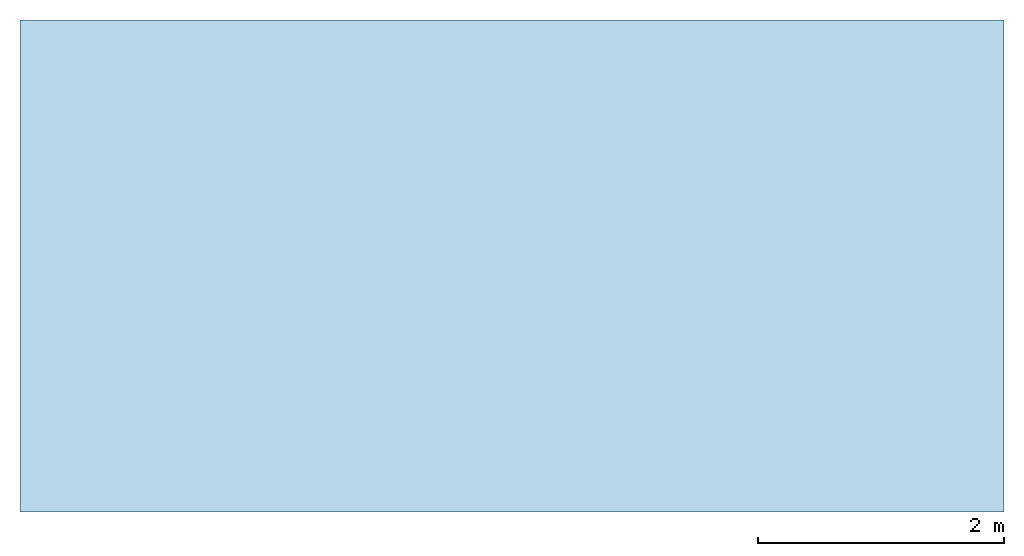
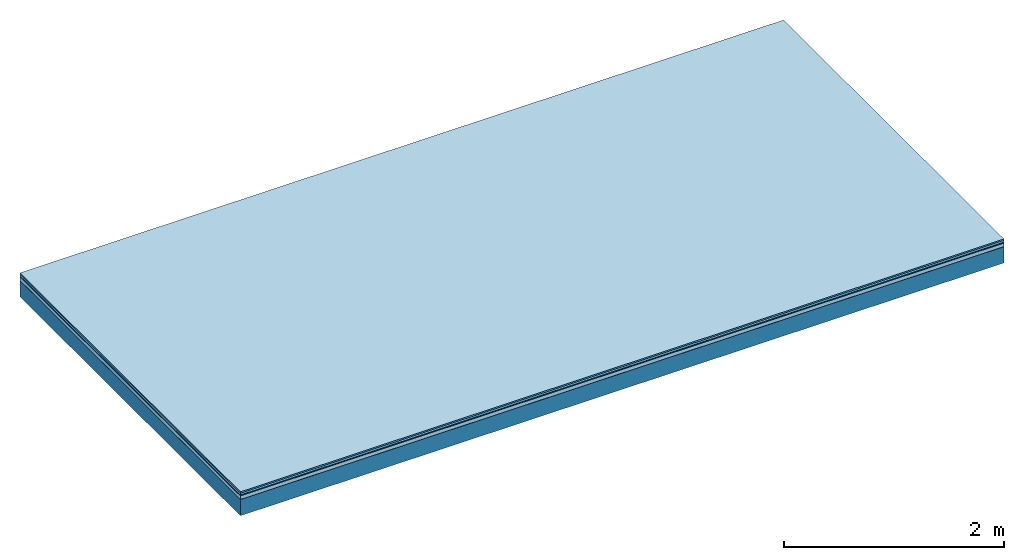
# One storey: 5 plates, 1 member, 1 element without a shape of its own.
"""IFC4 building model written with IfcOpenShell, lengths in metres."""

from ifc_helpers import new_model, si_unit, derived_unit, direction, frame, frame_2d, origin, origin_with_axes, place, context, project, spatial, rectangle, extrude, material, layer, layer_set, type_object, element, aggregate, save


model = new_model("IFC4")

# Units and contexts
plan_context = context("Plan", 3, precision=1e-05, world=origin(), true_north=direction((0.0, 1.0)))
model_context = context("Model", 3, precision=1e-05, world=origin(), true_north=direction((0.0, 1.0)))
ifc_project = project(units=[si_unit("LENGTHUNIT", "METRE"), derived_unit("SOUNDPRESSUREUNIT", [(si_unit("PRESSUREUNIT", "PASCAL", prefix="MICRO"), 0)]), si_unit("ENERGYUNIT", "JOULE", prefix="MEGA"), si_unit("MASSUNIT", "GRAM", prefix="KILO"), derived_unit("THERMALTRANSMITTANCEUNIT", [(si_unit("POWERUNIT", "WATT"), 1), (si_unit("AREAUNIT", "SQUARE_METRE"), -1), (si_unit("THERMODYNAMICTEMPERATUREUNIT", "KELVIN"), -1)]), derived_unit("AREADENSITYUNIT", [(si_unit("MASSUNIT", "GRAM", prefix="KILO"), 1), (si_unit("AREAUNIT", "SQUARE_METRE"), -1)]), derived_unit("USERDEFINED", [(si_unit("ENERGYUNIT", "JOULE", prefix="MEGA"), 1), (si_unit("AREAUNIT", "SQUARE_METRE"), -1)])], contexts=[plan_context, model_context])

# Site, building, storey
site = spatial("IfcSite", under=ifc_project)
building_placement = place(None, origin())
building = spatial("IfcBuilding", under=site, at=building_placement)
storey_placement = place(building_placement, origin())
storey = spatial("IfcBuildingStorey", under=building, at=storey_placement)

# Slab, member, plates
ifc_material_1 = material(Category="11.013")
ifc_layer_1 = layer(ifc_material_1, 0.015, Name="Flooring")
ifc_material_2 = material(Category="03.007")
ifc_layer_2 = layer(ifc_material_2, 0.02, Name="On-material")
ifc_material_3 = material(Name="Wood fiber generic product", Category="10.009")
ifc_layer_3 = layer(ifc_material_3, 0.01, Name="Impact sound insulation")
ifc_material_4 = material(Name="Cement panels, glued on sub-floor", Category="02.007")
ifc_layer_4 = layer(ifc_material_4, 0.04, Name="on Supporting structure")
ifc_material_5 = material(Name="protection", Category="09.007")
ifc_layer_5 = layer(ifc_material_5, 0.0005, Name="Sub-floor")
ifc_material_6 = material(Name="no composite action")
ifc_layer_6 = layer(ifc_material_6, 0.0, Name="Bond")
ifc_layer_7 = layer(None, 0.18, Name="Supporting structure")
ifc_layer_set = layer_set([ifc_layer_1, ifc_layer_2, ifc_layer_3, ifc_layer_4, ifc_layer_5, ifc_layer_6, ifc_layer_7])
slab_type = type_object("IfcSlabType", Name="A2063", PredefinedType="NOTDEFINED", material=ifc_layer_set)
slab_placement = place(None, frame((0.0, 0.0, 0.0), z_axis=(0.0, 0.0, -1.0), x_axis=(1.0, 0.0, 0.0)))
slab = element("IfcSlab", 1, at=slab_placement, inside=storey, type_object=slab_type, material=ifc_layer_set, Name="Slab #1")
ifc_material_7 = material(Name="Solid timber panel")
member_placement = place(slab_placement, origin())
member = element("IfcMember", 2, at=member_placement, material=ifc_material_7, Name="Supporting structure", context=plan_context, shape_type="SweptSolid", body=[
    extrude(rectangle(XDim=1.0, YDim=0.18, at=frame_2d((0.5, 0.09), x_axis=(1.0, 0.0))), frame((0.0, 4.0, 0.0855), z_axis=(0.0, -1.0, 0.0), x_axis=(1.0, 0.0, 0.0)), (0.0, 0.0, 1.0), 4.0),
    extrude(rectangle(XDim=1.0, YDim=0.18, at=frame_2d((0.5, 0.09), x_axis=(1.0, 0.0))), frame((1.0, 4.0, 0.0855), z_axis=(0.0, -1.0, 0.0), x_axis=(1.0, 0.0, 0.0)), (0.0, 0.0, 1.0), 4.0),
    extrude(rectangle(XDim=1.0, YDim=0.18, at=frame_2d((0.5, 0.09), x_axis=(1.0, 0.0))), frame((2.0, 4.0, 0.0855), z_axis=(0.0, -1.0, 0.0), x_axis=(1.0, 0.0, 0.0)), (0.0, 0.0, 1.0), 4.0),
    extrude(rectangle(XDim=1.0, YDim=0.18, at=frame_2d((0.5, 0.09), x_axis=(1.0, 0.0))), frame((3.0, 4.0, 0.0855), z_axis=(0.0, -1.0, 0.0), x_axis=(1.0, 0.0, 0.0)), (0.0, 0.0, 1.0), 4.0),
    extrude(rectangle(XDim=1.0, YDim=0.18, at=frame_2d((0.5, 0.09), x_axis=(1.0, 0.0))), frame((4.0, 4.0, 0.0855), z_axis=(0.0, -1.0, 0.0), x_axis=(1.0, 0.0, 0.0)), (0.0, 0.0, 1.0), 4.0),
    extrude(rectangle(XDim=1.0, YDim=0.18, at=frame_2d((0.5, 0.09), x_axis=(1.0, 0.0))), frame((5.0, 4.0, 0.0855), z_axis=(0.0, -1.0, 0.0), x_axis=(1.0, 0.0, 0.0)), (0.0, 0.0, 1.0), 4.0),
    extrude(rectangle(XDim=1.0, YDim=0.18, at=frame_2d((0.5, 0.09), x_axis=(1.0, 0.0))), frame((6.0, 4.0, 0.0855), z_axis=(0.0, -1.0, 0.0), x_axis=(1.0, 0.0, 0.0)), (0.0, 0.0, 1.0), 4.0),
    extrude(rectangle(XDim=1.0, YDim=0.18, at=frame_2d((0.5, 0.09), x_axis=(1.0, 0.0))), frame((7.0, 4.0, 0.0855), z_axis=(0.0, -1.0, 0.0), x_axis=(1.0, 0.0, 0.0)), (0.0, 0.0, 1.0), 4.0),
])
plate_1_placement = place(slab_placement, origin())
plate_1 = element("IfcPlate", 3, at=plate_1_placement, material=ifc_material_1, Name="Flooring", context=plan_context, shape_type="SweptSolid", body=[
    extrude(rectangle(XDim=8.0, YDim=4.0, at=frame_2d((4.0, 2.0), x_axis=(1.0, 0.0))), origin_with_axes(), (0.0, 0.0, 1.0), 0.015),
])
plate_2_placement = place(slab_placement, origin())
plate_2 = element("IfcPlate", 4, at=plate_2_placement, material=ifc_material_2, Name="On-material", context=plan_context, shape_type="SweptSolid", body=[
    extrude(rectangle(XDim=8.0, YDim=4.0, at=frame_2d((4.0, 2.0), x_axis=(1.0, 0.0))), frame((0.0, 0.0, 0.015), z_axis=(0.0, 0.0, 1.0), x_axis=(1.0, 0.0, 0.0)), (0.0, 0.0, 1.0), 0.02),
])
plate_3_placement = place(slab_placement, origin())
plate_3 = element("IfcPlate", 5, at=plate_3_placement, material=ifc_material_3, Name="Impact sound insulation", context=plan_context, shape_type="SweptSolid", body=[
    extrude(rectangle(XDim=8.0, YDim=4.0, at=frame_2d((4.0, 2.0), x_axis=(1.0, 0.0))), frame((0.0, 0.0, 0.035), z_axis=(0.0, 0.0, 1.0), x_axis=(1.0, 0.0, 0.0)), (0.0, 0.0, 1.0), 0.01),
])
plate_4_placement = place(slab_placement, origin())
plate_4 = element("IfcPlate", 6, at=plate_4_placement, material=ifc_material_4, Name="on Supporting structure", context=plan_context, shape_type="SweptSolid", body=[
    extrude(rectangle(XDim=8.0, YDim=4.0, at=frame_2d((4.0, 2.0), x_axis=(1.0, 0.0))), frame((0.0, 0.0, 0.045), z_axis=(0.0, 0.0, 1.0), x_axis=(1.0, 0.0, 0.0)), (0.0, 0.0, 1.0), 0.04),
])
plate_5_placement = place(slab_placement, origin())
plate_5 = element("IfcPlate", 7, at=plate_5_placement, material=ifc_material_5, Name="Sub-floor", context=plan_context, shape_type="SweptSolid", body=[
    extrude(rectangle(XDim=8.0, YDim=4.0, at=frame_2d((4.0, 2.0), x_axis=(1.0, 0.0))), frame((0.0, 0.0, 0.085), z_axis=(0.0, 0.0, 1.0), x_axis=(1.0, 0.0, 0.0)), (0.0, 0.0, 1.0), 0.0005),
])
aggregate(slab, [plate_1, plate_2, plate_3, plate_4, plate_5, member])

save(model, "model.ifc")
